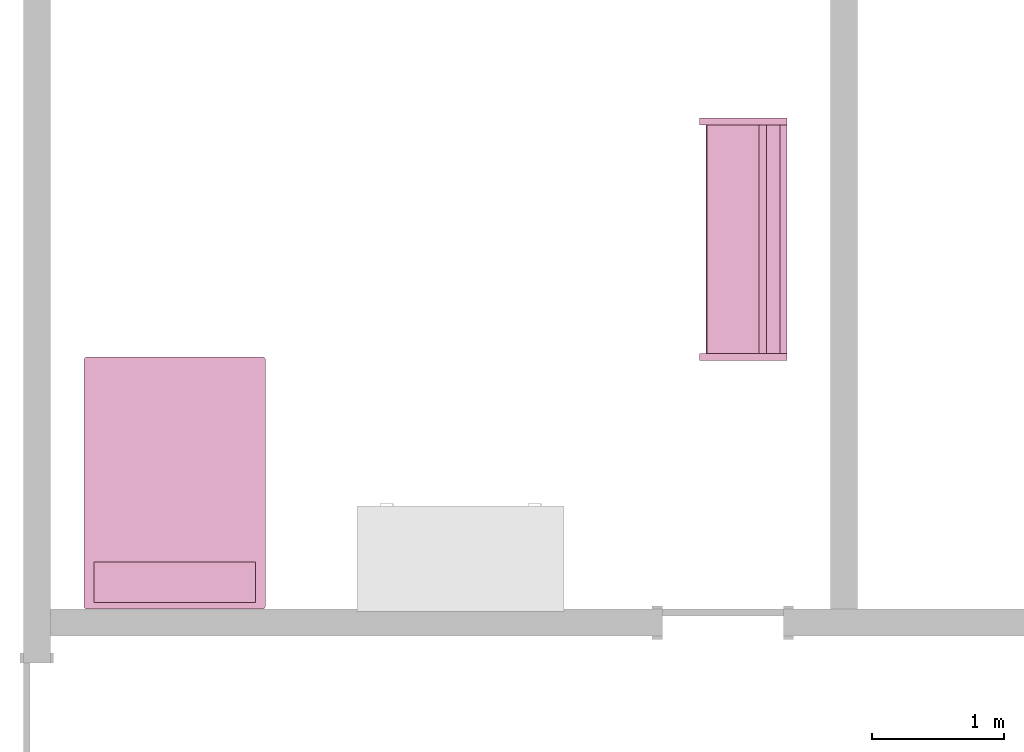
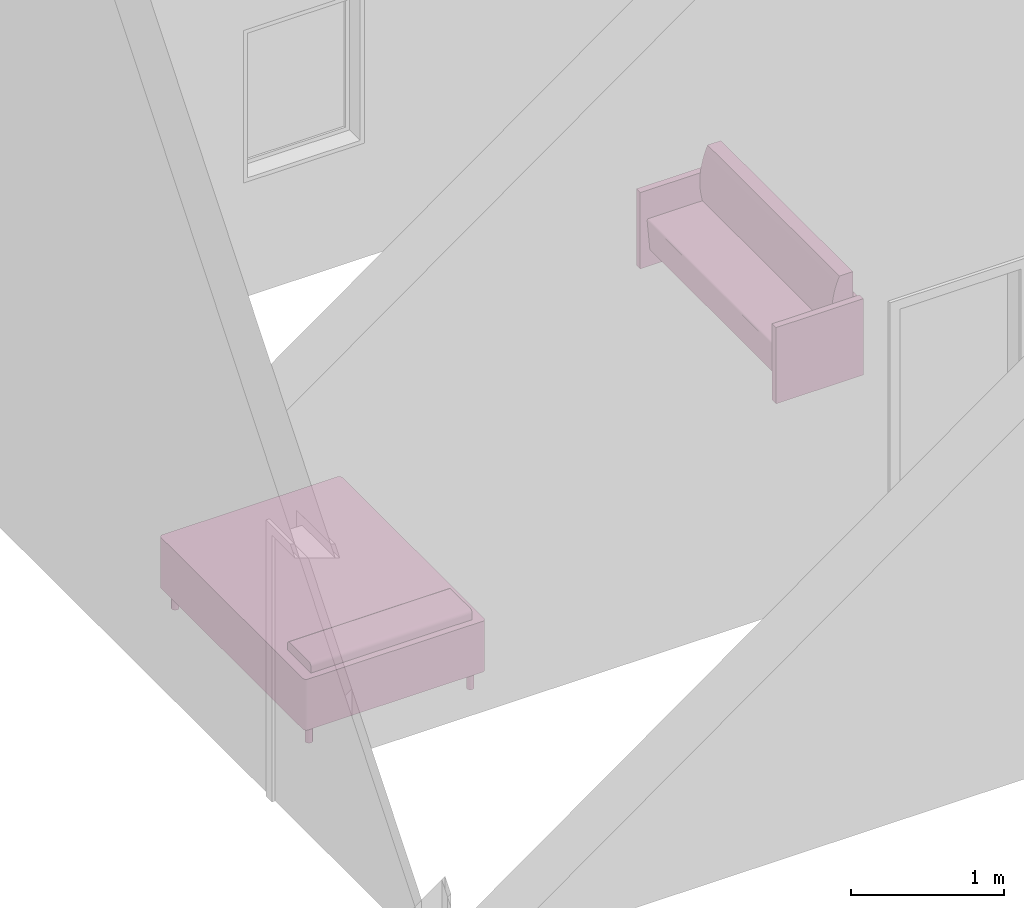
# One storey, part 3 of 4: 2 furnishings.
"""IFC2X3 building model written with IfcOpenShell, lengths in feet."""

from ifc_helpers import new_model, entity, si_unit, converted_unit, derived_unit, direction, frame, frame_2d, origin, origin_2d_with_axis, place, context, subcontext, project, spatial, polyline, circle_curve, parameter, trimmed, segment, composite_curve, rectangle, circle, outline, extrude, source, transform, mapped, material, material_list, type_object, type_shapes, element, save


model = new_model("IFC2X3")

# Units and contexts
model_context = context("Model", 3, precision=0.0001, world=origin(), true_north=direction((6.123031769111886e-17, 1.0)))
body_context = subcontext(model_context, "Body", "Model", "MODEL_VIEW")
ifc_project = project(units=[converted_unit("LENGTHUNIT", "FOOT", entity("IfcRatioMeasure", 0.3048), si_unit("LENGTHUNIT", "METRE"), dimensions=[1, 0, 0, 0, 0, 0, 0]), converted_unit("AREAUNIT", "SQUARE FOOT", entity("IfcRatioMeasure", 0.09290304), si_unit("AREAUNIT", "SQUARE_METRE"), dimensions=[2, 0, 0, 0, 0, 0, 0]), converted_unit("VOLUMEUNIT", "CUBIC FOOT", entity("IfcRatioMeasure", 0.028316846592000004), si_unit("VOLUMEUNIT", "CUBIC_METRE"), dimensions=[3, 0, 0, 0, 0, 0, 0]), converted_unit("PLANEANGLEUNIT", "DEGREE", entity("IfcRatioMeasure", 0.017453292519943278), si_unit("PLANEANGLEUNIT", "RADIAN"), dimensions=[0, 0, 0, 0, 0, 0, 0]), si_unit("MASSUNIT", "GRAM", prefix="KILO"), derived_unit("MASSDENSITYUNIT", [(si_unit("MASSUNIT", "GRAM", prefix="KILO"), 1), (si_unit("LENGTHUNIT", "METRE"), -3)]), derived_unit("MOMENTOFINERTIAUNIT", [(si_unit("LENGTHUNIT", "METRE"), 4)]), si_unit("TIMEUNIT", "SECOND"), si_unit("FREQUENCYUNIT", "HERTZ"), si_unit("THERMODYNAMICTEMPERATUREUNIT", "DEGREE_CELSIUS"), derived_unit("THERMALTRANSMITTANCEUNIT", [(si_unit("MASSUNIT", "GRAM", prefix="KILO"), 1), (si_unit("THERMODYNAMICTEMPERATUREUNIT", "KELVIN"), -1), (si_unit("TIMEUNIT", "SECOND"), -3)]), derived_unit("VOLUMETRICFLOWRATEUNIT", [(si_unit("LENGTHUNIT", "METRE"), 3), (si_unit("TIMEUNIT", "SECOND"), -1)]), derived_unit("MASSFLOWRATEUNIT", [(si_unit("MASSUNIT", "GRAM", prefix="KILO"), 1), (si_unit("TIMEUNIT", "SECOND"), -1)]), derived_unit("ROTATIONALFREQUENCYUNIT", [(si_unit("TIMEUNIT", "SECOND"), -1)]), si_unit("ELECTRICCURRENTUNIT", "AMPERE"), si_unit("ELECTRICVOLTAGEUNIT", "VOLT"), si_unit("POWERUNIT", "WATT"), si_unit("FORCEUNIT", "NEWTON"), si_unit("ILLUMINANCEUNIT", "LUX"), si_unit("LUMINOUSFLUXUNIT", "LUMEN"), si_unit("LUMINOUSINTENSITYUNIT", "CANDELA"), derived_unit("USERDEFINED", [(si_unit("MASSUNIT", "GRAM", prefix="KILO"), -1), (si_unit("LENGTHUNIT", "METRE"), -2), (si_unit("TIMEUNIT", "SECOND"), 3), (si_unit("LUMINOUSFLUXUNIT", "LUMEN"), 1)]), derived_unit("SOUNDPOWERUNIT", [(si_unit("MASSUNIT", "GRAM", prefix="KILO"), 1), (si_unit("LENGTHUNIT", "METRE"), 2), (si_unit("TIMEUNIT", "SECOND"), -3)]), derived_unit("SOUNDPRESSUREUNIT", [(si_unit("MASSUNIT", "GRAM", prefix="KILO"), 1), (si_unit("LENGTHUNIT", "METRE"), -1), (si_unit("TIMEUNIT", "SECOND"), -2)]), derived_unit("LINEARVELOCITYUNIT", [(si_unit("LENGTHUNIT", "METRE"), 1), (si_unit("TIMEUNIT", "SECOND"), -1)]), si_unit("PRESSUREUNIT", "PASCAL"), derived_unit("USERDEFINED", [(si_unit("LENGTHUNIT", "METRE"), -2), (si_unit("MASSUNIT", "GRAM", prefix="KILO"), 1), (si_unit("TIMEUNIT", "SECOND"), -2)]), derived_unit("LINEARFORCEUNIT", [(si_unit("MASSUNIT", "GRAM", prefix="KILO"), 1), (si_unit("LENGTHUNIT", "METRE"), 1), (si_unit("TIMEUNIT", "SECOND"), -2), (si_unit("LENGTHUNIT", "METRE"), -1)]), derived_unit("PLANARFORCEUNIT", [(si_unit("MASSUNIT", "GRAM", prefix="KILO"), 1), (si_unit("LENGTHUNIT", "METRE"), 1), (si_unit("TIMEUNIT", "SECOND"), -2), (si_unit("LENGTHUNIT", "METRE"), -2)])], contexts=[model_context])

# Site, building, storey, space
site_placement = place(None, origin())
site = spatial("IfcSite", under=ifc_project, at=site_placement, CompositionType="ELEMENT")
building_placement = place(site_placement, origin())
building = spatial("IfcBuilding", under=site, at=building_placement, CompositionType="ELEMENT")
storey_placement = place(building_placement, origin())
storey = spatial("IfcBuildingStorey", under=building, at=storey_placement, Name="Level 1", CompositionType="ELEMENT", Elevation=0.0)
space_placement = place(storey_placement, origin())
space = spatial("IfcSpace", under=storey, at=space_placement, CompositionType="ELEMENT", InteriorOrExteriorSpace="INTERNAL")

# Furnishings
ifc_material_1 = material(Name="Linen, White")
ifc_material_2 = material(Name="Steel, Chrome Plated")
ifc_material_list_1 = material_list([ifc_material_1, ifc_material_1, ifc_material_2, ifc_material_2, ifc_material_2, ifc_material_2, ifc_material_1])
ifc_material_list_2 = material_list([ifc_material_1, ifc_material_1, ifc_material_2, ifc_material_2, ifc_material_2, ifc_material_2, ifc_material_1])
furniture_type_1 = type_object("IfcFurnitureType", material=ifc_material_list_2)
shared_shape_1 = source(origin(), body_context, "Body", "SweptSolid", [
    extrude(outline(composite_curve([segment(trimmed(circle_curve(frame_2d((-2.1666666666666727, -3.0416666666666905), x_axis=(1.0, 0.0)), 0.0833333333333345), [parameter(179.9999999999999)], [parameter(269.9999999999996)], True, "PARAMETER"), True, "CONTINUOUS"), segment(polyline([(-2.166666666666673, -3.125000000000025), (2.1666666666667282, -3.1250000000000253)]), True, "CONTINUOUS"), segment(trimmed(circle_curve(frame_2d((2.1666666666667282, -3.0416666666667633), x_axis=(1.0, 0.0)), 0.08333333333326298), [parameter(269.9999999999993)], [parameter(359.9999999999997)], True, "PARAMETER"), True, "CONTINUOUS"), segment(polyline([(2.249999999999991, -3.0416666666667633), (2.2499999999999902, 3.04166666666678)]), True, "CONTINUOUS"), segment(trimmed(circle_curve(frame_2d((2.1666666666667997, 3.0416666666667806), x_axis=(1.0, 0.0)), 0.08333333333318958), [parameter(359.9999999999997)], [parameter(89.99999999999979)], True, "PARAMETER"), True, "CONTINUOUS"), segment(polyline([(2.1666666666667997, 3.1249999999999702), (-2.16666666666682, 3.124999999999972)]), True, "CONTINUOUS"), segment(trimmed(circle_curve(frame_2d((-2.1666666666668197, 3.0416666666667838), x_axis=(1.0, 0.0)), 0.08333333333318739), [parameter(89.99999999999979)], [parameter(179.99999999999957)], True, "PARAMETER"), True, "CONTINUOUS"), segment(polyline([(-2.250000000000007, 3.0416666666667846), (-2.2500000000000075, -3.0416666666666905)]), True, "CONTINUOUS")], self_intersect=False)), frame((0.890710382513678, -0.14959016393436586, 0.5)), (0.0, 0.0, 1.0), 0.6666666666666667),
    extrude(outline(composite_curve([segment(polyline([(-0.5000000000000004, -0.13888888888888884), (0.5, -0.13888888888888884)]), True, "CONTINUOUS"), segment(polyline([(0.5, -0.13888888888888884), (0.5, 0.027777777777778123)]), True, "CONTINUOUS"), segment(trimmed(circle_curve(frame_2d((0.4166666666666665, 0.027777777777778123), x_axis=(-1.0, 0.0)), 0.08333333333333333), [parameter(179.99999999999983)], [parameter(269.9999999999999)], True, "PARAMETER"), True, "CONTINUOUS"), segment(polyline([(0.4166666666666665, 0.1111111111111116), (-0.41666666666666674, 0.11111111111111116)]), True, "CONTINUOUS"), segment(trimmed(circle_curve(frame_2d((-0.41666666666666674, 0.02777777777777768), x_axis=(-1.0, 0.0)), 0.08333333333333333), [parameter(269.9999999999999)], [parameter(0.0)], True, "PARAMETER"), True, "CONTINUOUS"), segment(polyline([(-0.5000000000000004, 0.02777777777777768), (-0.5000000000000004, -0.13888888888888884)]), True, "CONTINUOUS")], self_intersect=False)), frame((-1.1092896174862394, 2.308743169398996, 1.9722222222222223), z_axis=(1.0, 0.0, 0.0), x_axis=(0.0, 1.0, 0.0)), (0.0, 0.0, 1.0), 3.999999999999914),
    extrude(circle(Radius=0.0833333333333331, at=frame_2d((0.0, 8.881784197001252e-16), x_axis=(1.0, 0.0))), frame((2.890710382513725, -3.024590163934308, 0.0)), (0.0, 0.0, 1.0), 0.5),
    extrude(circle(Radius=0.08333333333340279, at=frame_2d((0.0, 4.440892098500626e-16), x_axis=(1.0, 0.0))), frame((2.8907103825136664, 2.725409836065683, 0.0)), (0.0, 0.0, 1.0), 0.5),
    extrude(circle(Radius=0.08333333333333283, at=frame_2d((-2.220446049250313e-16, 4.440892098500626e-16), x_axis=(1.0, 0.0))), frame((-1.1092896174863185, 2.7254098360656043, 0.0)), (0.0, 0.0, 1.0), 0.5),
    extrude(circle(Radius=0.08333333333334278, at=frame_2d((0.0, 4.440892098500626e-16), x_axis=(1.0, 0.0))), frame((-1.1092896174862488, -3.024590163934401, 0.0)), (0.0, 0.0, 1.0), 0.5),
    extrude(outline(composite_curve([segment(trimmed(circle_curve(frame_2d((-2.1666666666667913, 3.0416666666667043), x_axis=(1.0, 0.0)), 0.08333333333318906), [parameter(90.00000000000009)], [parameter(179.99999999999957)], True, "PARAMETER"), True, "CONTINUOUS"), segment(polyline([(-2.2499999999999805, 3.041666666666705), (-2.2500000000000537, -3.041666666666612)]), True, "CONTINUOUS"), segment(trimmed(circle_curve(frame_2d((-2.1666666666666345, -3.041666666666611), x_axis=(1.0, 0.0)), 0.08333333333333548), [parameter(180.00000000000017)], [parameter(269.9999999999996)], True, "PARAMETER"), True, "CONTINUOUS"), segment(polyline([(-2.166666666666635, -3.1249999999999467), (2.166666666666691, -3.12500000000003)]), True, "CONTINUOUS"), segment(trimmed(circle_curve(frame_2d((2.166666666666691, -3.0416666666667767), x_axis=(1.0, 0.0)), 0.08333333333326289), [parameter(269.9999999999999)], [parameter(359.9999999999997)], True, "PARAMETER"), True, "CONTINUOUS"), segment(polyline([(2.249999999999954, -3.0416666666667767), (2.249999999999945, 3.0416666666667953)]), True, "CONTINUOUS"), segment(trimmed(circle_curve(frame_2d((2.166666666666772, 3.0416666666667944), x_axis=(1.0, 0.0)), 0.08333333333318749), [parameter(359.9999999999997)], [parameter(89.99999999999979)], True, "PARAMETER"), True, "CONTINUOUS"), segment(polyline([(2.1666666666667727, 3.124999999999982), (-2.1666666666667913, 3.1249999999999667)]), True, "CONTINUOUS")], self_intersect=False)), frame((0.8907103825137241, -0.14959016393436114, 1.1666666666666667)), (0.0, 0.0, 1.0), 0.6666666666666667),
])
type_shapes(furniture_type_1, [shared_shape_1])
furnishing_1_placement = place(space_placement, frame((-34.78214280352263, 16.567481285455994, 0.0), z_axis=(0.0, 0.0, 1.0), x_axis=(-1.0, 0.0, 0.0)))
element("IfcFurnishingElement", 1, at=furnishing_1_placement, inside=space, type_object=furniture_type_1, material=ifc_material_list_1, context=body_context, shape_type="MappedRepresentation", body=[
    mapped(shared_shape_1, transform((0.0, 0.0, 0.0), scale=1.0)),
])
ifc_material_3 = material(Name="Cherry")
ifc_material_4 = material(Name="Linen, Beige")
ifc_material_list_3 = material_list([ifc_material_3, ifc_material_3, ifc_material_3, ifc_material_4, ifc_material_3, ifc_material_3])
ifc_material_list_4 = material_list([ifc_material_3, ifc_material_3, ifc_material_3, ifc_material_4, ifc_material_3, ifc_material_3])
furniture_type_2 = type_object("IfcFurnitureType", material=ifc_material_list_4)
shared_shape_2 = source(origin(), body_context, "Body", "SweptSolid", [
    extrude(rectangle(XDim=5.666666666666626, YDim=0.1666666666666723, at=frame_2d((0.0, 1.1102230246251565e-16), x_axis=(1.0, 0.0))), frame((0.23087431693990657, 1.4795081967213082, 1.5)), (0.0, 0.0, 1.0), 0.41666666666666674),
    extrude(rectangle(XDim=5.666666666666626, YDim=0.16666666666666918, at=frame_2d((0.0, -1.1102230246251565e-16), x_axis=(1.0, 0.0))), frame((0.23087431693990657, 1.47950819672131, 0.875)), (0.0, 0.0, 1.0), 0.41666666666666674),
    extrude(rectangle(XDim=5.666666666666626, YDim=0.16666666666664653, at=frame_2d((0.0, 1.1102230246251565e-16), x_axis=(1.0, 0.0))), frame((0.23087431693990657, 1.479508196721321, 0.25)), (0.0, 0.0, 1.0), 0.41666666666666674),
    extrude(outline(composite_curve([segment(polyline([(-0.4239450921530974, 0.16110152579512826), (0.906641446974003, 0.16110152579512826)]), True, "CONTINUOUS"), segment(trimmed(circle_curve(frame_2d((0.906641446974003, 0.202768192461795), x_axis=(1.0, 0.0)), 0.041666666666666685), [parameter(269.9999999999999)], [parameter(4.999999999999999)], True, "PARAMETER"), True, "CONTINUOUS"), segment(polyline([(0.9481495593944929, 0.2063996817429472), (0.879482848895504, 0.99126377420492)]), True, "CONTINUOUS"), segment(polyline([(0.879482848895504, 0.99126377420492), (-0.8812206988147708, 0.9912637742049197)]), True, "CONTINUOUS"), segment(polyline([(-0.8812206988147708, 0.9912637742049197), (-0.8812206988147708, -1.2555651408715285)]), True, "CONTINUOUS"), segment(polyline([(-0.8812206988147708, -1.2555651408715285), (-0.547887365481361, -1.2555651408715165)]), True, "CONTINUOUS"), segment(trimmed(circle_curve(frame_2d((-2.524800422095059, -0.36885255438436726), x_axis=(1.0, 0.0)), 2.1666666666666665), [parameter(335.8421470544958)], [parameter(14.157852945514689)], True, "PARAMETER"), True, "CONTINUOUS")], self_intersect=False)), frame((-2.6024590163934085, 0.5149541645732114, 1.4111015257951327), z_axis=(1.0, 0.0, 0.0), x_axis=(0.0, -1.0, 0.0)), (0.0, 0.0, 1.0), 5.666666666666624),
    extrude(rectangle(XDim=2.166666666666656, YDim=0.16666666666670116, at=frame_2d((0.0, 2.220446049250313e-16), x_axis=(1.0, 0.0))), frame((-2.6857923497267593, 0.47950819672131173, 0.0), z_axis=(0.0, 0.0, 1.0), x_axis=(0.0, -1.0, 0.0)), (0.0, 0.0, 1.0), 2.0),
    extrude(rectangle(XDim=0.16666666666675312, YDim=2.1666666666666687, at=origin_2d_with_axis()), frame((3.1475409836065493, 0.4795081967214571, 0.0), z_axis=(0.0, 0.0, 1.0), x_axis=(-1.0, 0.0, 0.0)), (0.0, 0.0, 1.0), 2.0),
])
type_shapes(furniture_type_2, [shared_shape_2])
furnishing_2_placement = place(space_placement, frame((-22.069028049424276, 22.98961243299691, 0.0), z_axis=(0.0, 0.0, 1.0), x_axis=(0.0, -1.0, 0.0)))
element("IfcFurnishingElement", 2, at=furnishing_2_placement, inside=space, type_object=furniture_type_2, material=ifc_material_list_3, context=body_context, shape_type="MappedRepresentation", body=[
    mapped(shared_shape_2, transform((0.0, 0.0, 0.0), scale=1.0)),
])

save(model, "model.ifc")
